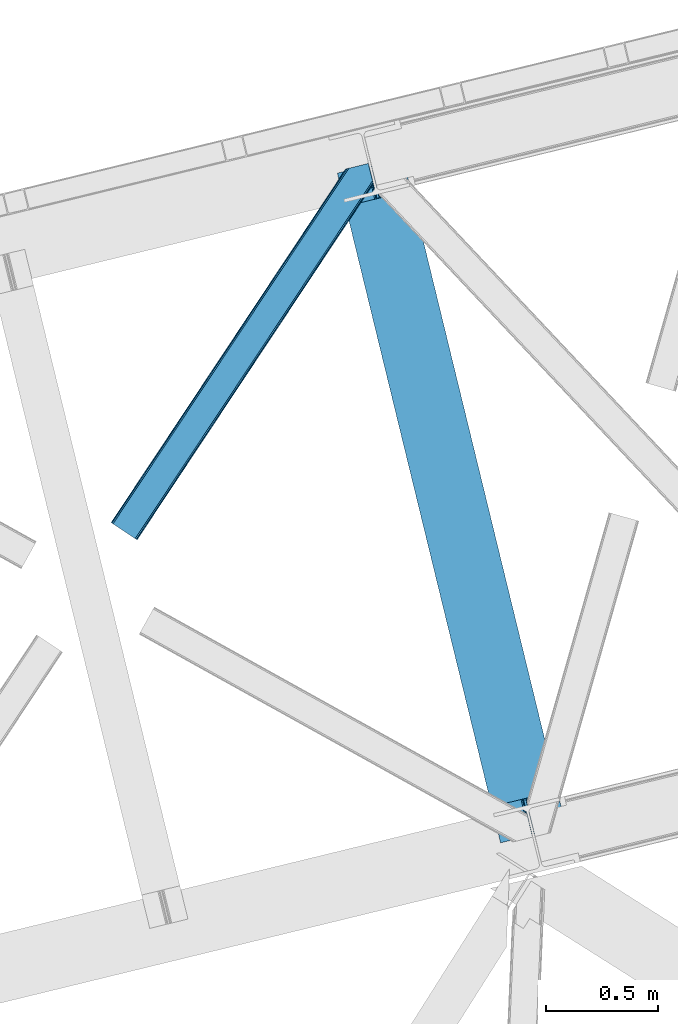
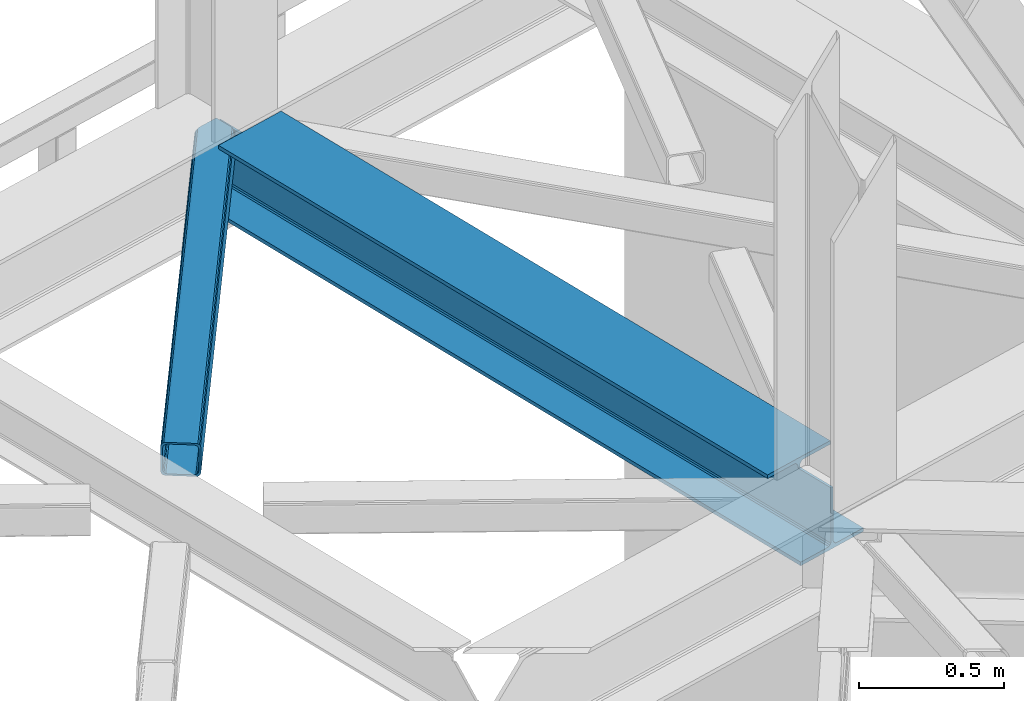
# One storey, part 84 of 92: 1 beam, 1 member.
"""IFC4 building model written with IfcOpenShell, lengths in millimetres."""

from ifc_helpers import new_model, entity, si_unit, converted_unit, derived_unit, direction, frame, origin, place, context, subcontext, project, spatial, triangles, polygons, material, type_object, element, save


model = new_model("IFC4")

# Units and contexts
model_context = context("Model", 3, precision=0.01, world=origin(), true_north=direction((6.12303176911189e-17, 1.0)))
plan_context = context("Plan", 3, precision=0.01, world=origin(), true_north=direction((6.12303176911189e-17, 1.0)))
body_context = subcontext(model_context, "Body", "Model", "MODEL_VIEW")
ifc_project = project(units=[si_unit("LENGTHUNIT", "METRE", prefix="MILLI"), si_unit("AREAUNIT", "SQUARE_METRE"), si_unit("VOLUMEUNIT", "CUBIC_METRE"), converted_unit("PLANEANGLEUNIT", "DEGREE", entity("IfcRatioMeasure", 0.0174532925199433), si_unit("PLANEANGLEUNIT", "RADIAN"), dimensions=[0, 0, 0, 0, 0, 0, 0]), si_unit("MASSUNIT", "GRAM", prefix="KILO"), derived_unit("MASSDENSITYUNIT", [(si_unit("MASSUNIT", "GRAM", prefix="KILO"), 1), (si_unit("LENGTHUNIT", "METRE"), -3)]), derived_unit("MOMENTOFINERTIAUNIT", [(si_unit("LENGTHUNIT", "METRE"), 4)]), si_unit("TIMEUNIT", "SECOND"), si_unit("FREQUENCYUNIT", "HERTZ"), si_unit("THERMODYNAMICTEMPERATUREUNIT", "DEGREE_CELSIUS"), derived_unit("THERMALTRANSMITTANCEUNIT", [(si_unit("MASSUNIT", "GRAM", prefix="KILO"), 1), (si_unit("THERMODYNAMICTEMPERATUREUNIT", "KELVIN"), -1), (si_unit("TIMEUNIT", "SECOND"), -3)]), derived_unit("VOLUMETRICFLOWRATEUNIT", [(si_unit("LENGTHUNIT", "METRE"), 3), (si_unit("TIMEUNIT", "SECOND"), -1)]), derived_unit("MASSFLOWRATEUNIT", [(si_unit("MASSUNIT", "GRAM", prefix="KILO"), 1), (si_unit("TIMEUNIT", "SECOND"), -1)]), derived_unit("ROTATIONALFREQUENCYUNIT", [(si_unit("TIMEUNIT", "SECOND"), -1)]), si_unit("ELECTRICCURRENTUNIT", "AMPERE"), si_unit("ELECTRICVOLTAGEUNIT", "VOLT"), si_unit("POWERUNIT", "WATT"), si_unit("FORCEUNIT", "NEWTON", prefix="KILO"), si_unit("ILLUMINANCEUNIT", "LUX"), si_unit("LUMINOUSFLUXUNIT", "LUMEN"), si_unit("LUMINOUSINTENSITYUNIT", "CANDELA"), derived_unit("USERDEFINED", [(si_unit("MASSUNIT", "GRAM", prefix="KILO"), -1), (si_unit("LENGTHUNIT", "METRE"), -2), (si_unit("TIMEUNIT", "SECOND"), 3), (si_unit("LUMINOUSFLUXUNIT", "LUMEN"), 1)]), derived_unit("LINEARVELOCITYUNIT", [(si_unit("LENGTHUNIT", "METRE"), 1), (si_unit("TIMEUNIT", "SECOND"), -1)]), si_unit("PRESSUREUNIT", "PASCAL"), derived_unit("USERDEFINED", [(si_unit("LENGTHUNIT", "METRE"), -2), (si_unit("MASSUNIT", "GRAM", prefix="KILO"), 1), (si_unit("TIMEUNIT", "SECOND"), -2)]), derived_unit("LINEARFORCEUNIT", [(si_unit("MASSUNIT", "GRAM", prefix="KILO"), 1), (si_unit("LENGTHUNIT", "METRE"), 1), (si_unit("TIMEUNIT", "SECOND"), -2), (si_unit("LENGTHUNIT", "METRE"), -1)]), derived_unit("PLANARFORCEUNIT", [(si_unit("MASSUNIT", "GRAM", prefix="KILO"), 1), (si_unit("LENGTHUNIT", "METRE"), 1), (si_unit("TIMEUNIT", "SECOND"), -2), (si_unit("LENGTHUNIT", "METRE"), -2)])], contexts=[model_context, plan_context])

# Site, building, storey
site_placement = place(None, origin())
site = spatial("IfcSite", under=ifc_project, at=site_placement, CompositionType="ELEMENT")
building_placement = place(site_placement, origin())
building = spatial("IfcBuilding", under=site, at=building_placement, CompositionType="ELEMENT")
storey_placement = place(building_placement, frame((0.0, 0.0, 15900.0)))
storey = spatial("IfcBuildingStorey", under=building, at=storey_placement, Name="05", CompositionType="ELEMENT", Elevation=15900.0)

# Beam
ifc_material = material(Name="Metal painted (White)")
beam_type = type_object("IfcBeamType", PredefinedType="BEAM")
beam_placement = place(storey_placement, frame((-3043.28, 17053.1, 3385.0)))
element("IfcBeam", 1, at=beam_placement, inside=storey, type_object=beam_type, material=ifc_material, ObjectType="Steel Beam", PredefinedType="BEAM", context=body_context, shape_type="Tessellation", body=[
    polygons([(1018.16648378329, 71.0478278971, 15.4999999999986), (1018.16648378329, 71.0478278971, 0.0), (291.465617442441, 3052.25531830421, 0.0), (291.46561744244, 3052.25531830421, 15.4999999999986), (894.779372399327, 40.970914087327, 15.4999999999986), (168.078506058477, 3022.17840449444, 15.4999999999986), (888.087028625373, 39.3395844888221, 16.8701684147941), (161.386162284522, 3020.54707489593, 16.8701684147941), (882.413533524753, 37.9566100336519, 20.7720779386369), (155.712667183903, 3019.16410044076, 20.7720779386369), (878.622625296174, 37.032536045914, 26.6116982174294), (151.921758955324, 3018.24002645303, 26.6116982174294), (877.29143535278, 36.7080444135029, 33.500000000001), (150.59056901193, 3017.91553482061, 33.500000000001), (140.875048430515, 3015.54727389071, 33.500000000001), (140.875048430516, 3015.54727389071, 259.000000000002), (150.590569011928, 3017.91553482061, 259.000000000002), (5.41433564649196e-13, 2981.20749040711, 0.0), (1.08286712929839e-12, 2981.20749040711, 15.4999999999986), (123.387111383957, 3011.28440421688, 15.4999999999986), (130.079455157929, 3012.91573381539, 16.8701684147963), (135.752950258545, 3014.29870827056, 20.7720779386369), (139.543858487118, 3015.22278225829, 26.6116982174294), (877.291435352778, 36.7080444135029, 259.000000000002), (867.575914771367, 34.3397834835992, 259.000000000002), (867.575914771365, 34.3397834835992, 33.500000000001), (866.244724827968, 34.0152918511816, 26.6116982174294), (862.453816599395, 33.0912178634502, 20.7720779386369), (856.78032149878, 31.70824340828, 16.8701684147963), (850.087977724808, 30.0769138097708, 15.4999999999986), (726.700866340852, -2.16573425859679e-12, 15.4999999999986), (726.700866340851, -2.16573425859679e-12, 0.0), (838.124523615906, 197.385937999179, 259.069791973884), (186.469722099963, 2870.72539801218, 259.000000000002), (186.693115201815, 2869.8089536072, 259.61730333112), (186.705504045442, 2869.75812937344, 266.500003008253), (837.97934480814, 197.9814160017, 266.500002998871), (837.979694928892, 197.979979696968, 260.000004007589), (828.499586345875, 194.645865944432, 259.006343171919), (828.276216326112, 195.562317481909, 259.61730333112), (828.263827482483, 195.613141715683, 266.500003008253), (176.989986719785, 2867.38985508742, 266.500002998871), (176.989636599033, 2867.39129139215, 260.000004007589), (176.844830940693, 2867.98534020594, 259.07612046749), (176.754201518551, 2868.35713708228, 259.000000000002), (839.310832678069, 198.30468544639, 273.388305639783), (843.101109266761, 199.231350618303, 279.227924098781), (848.7741802143, 200.616065081979, 283.129832400619), (855.466371895431, 202.248018612794, 284.500000377228), (978.853400583269, 232.325271667903, 284.500000138971), (978.851730776618, 232.332121736637, 299.999995328161), (687.386308679348, 161.283492472594, 299.999995890962), (687.387978485999, 161.276642403861, 284.500000701776), (810.775007173834, 191.35389545897, 284.500000463519), (817.467494069994, 192.984637925553, 283.129832461069), (823.141405718745, 194.365903570076, 279.227924137322), (826.932940505739, 195.28740721937, 273.388305663684), (175.658498849857, 2867.06658564273, 273.388305639783), (171.868222261161, 2866.13992047082, 279.227924098781), (166.195151313635, 2864.75520600714, 283.129832400619), (159.502959632485, 2863.12325247633, 284.500000377228), (36.115930944656, 2833.04599942122, 284.500000138971), (36.117600751305, 2833.03914935249, 299.999995328161), (327.583022848576, 2904.08777861653, 299.999995890962), (327.581353041926, 2904.09462868526, 284.500000701776), (204.194324354083, 2874.01737563015, 284.500000463519), (197.501837457941, 2872.38663316357, 283.129832461069), (191.827925809177, 2871.00536751904, 279.227924137322), (188.036391022187, 2870.08386386975, 273.388305663684)], [[[1, 2, 3, 4]], [[5, 1, 4, 6]], [[7, 5, 6, 8]], [[9, 7, 8, 10]], [[11, 9, 10, 12]], [[13, 11, 12, 14]], [[15, 16, 17, 14, 12, 10, 8, 6, 4, 3, 18, 19, 20, 21, 22, 23]], [[13, 24, 25, 26, 27, 28, 29, 30, 31, 32, 2, 1, 5, 7, 9, 11]], [[2, 32, 18, 3]], [[32, 31, 19, 18]], [[31, 30, 20, 19]], [[27, 26, 15, 23]], [[28, 27, 23, 22]], [[29, 28, 22, 21]], [[30, 29, 21, 20]], [[33, 24, 13, 14, 17, 34, 35, 36, 37, 38]], [[25, 39, 40, 41, 42, 43, 44, 16, 15, 26]], [[39, 25, 24, 33]], [[45, 34, 17, 16]], [[41, 40, 38, 37, 46, 47, 48, 49, 50, 51, 52, 53, 54, 55, 56, 57]], [[42, 58, 59, 60, 61, 62, 63, 64, 65, 66, 67, 68, 69, 36, 35, 43]], [[46, 37, 36, 69]], [[47, 46, 69, 68]], [[48, 47, 68, 67]], [[49, 48, 67, 66]], [[50, 49, 66, 65]], [[51, 50, 65, 64]], [[52, 51, 64, 63]], [[53, 52, 63, 62]], [[54, 53, 62, 61]], [[55, 54, 61, 60]], [[56, 55, 60, 59]], [[57, 56, 59, 58]], [[41, 57, 58, 42]]], closed=False),
])

# Member
member_type = type_object("IfcMemberType", PredefinedType="BRACE")
member_placement = place(storey_placement, frame((-4050.77, 18401.58, 3510.02)))
element("IfcMember", 2, at=member_placement, inside=storey, type_object=member_type, ObjectType="Steel Horizontal Brace", PredefinedType="BRACE", context=body_context, shape_type="Tessellation", body=[
    triangles([(1012.13822021484, 1571.4587310791, 0.0), (1045.99690933228, 1432.55790710449, 0.0), (14.5796333312987, 67.7191223144546, 0.0), (102.080397033692, 9.67499084472729, 0.0), (1.10807189941397, 76.6569488525383, 10.8039916992202), (0.0, 77.3929504394546, 17.5000946044929), (1043.79529953003, 1650.83760681152, 17.5000946044929), (1007.73296585083, 1592.73185119629, 9.25873718261573), (4.27125091552716, 74.5605651855476, 5.12643127441333), (1007.87191085815, 1593.1829864502, 9.50058288574292), (1007.5829750061, 1592.24815979004, 9.00061340332104), (1007.43734436035, 1591.76446838379, 8.74248962402271), (1007.29839935303, 1591.31333312989, 8.50064392089917), (1008.14776611328, 1587.8298248291, 5.12643127441333), (1046.0907989502, 1651.39571228027, 10.8702667236321), (1046.56518859863, 1651.51198425293, 9.50058288574292), (1009.97875900269, 1580.31865539551, 1.33247680664135), (9.00003204345694, 71.4212219238289, 1.33247680664135), (1043.79529953003, 1650.83760681152, 122.499499511719), (0.0, 77.3929504394546, 122.499499511719), (1045.70215988159, 1651.30269470215, 129.196765136719), (1.10807189941397, 76.6569488525383, 129.196765136719), (1051.1335144043, 1652.62586975098, 134.87548828125), (4.27125091552716, 74.5605651855476, 134.87548828125), (1059.25772781372, 1654.60481872559, 138.668280029298), (9.00003204345694, 71.4212219238289, 138.668280029298), (1068.84609603882, 1656.94421081543, 140.000756835936), (14.5796333312987, 67.7191223144546, 140.000756835936), (1012.24141159058, 1575.25849914551, 9.50058288574292), (1011.99578704834, 1574.65621032715, 9.42384338378906), (1012.03008728027, 1573.63069152832, 9.11688537597729), (1012.0707824707, 1572.60052185059, 8.80760192871094), (1012.10973358154, 1571.57732849121, 8.50064392089917), (1065.96342315674, 1656.23960266114, 9.50058288574292), (14.8357223510743, 67.5516906738303, 8.3320495605476), (20.4150329589843, 63.8495910644524, 7.00073547363354), (1014.39534988403, 1562.19883117676, 7.00073547363354), (10.1022903442381, 70.6898712158218, 12.1260040283196), (1061.15121688843, 1655.06758117676, 12.1260040283196), (1012.24228363037, 1571.03317565918, 8.41343994140698), (1055.7242225647, 1653.74440612793, 17.8035644531265), (1053.81300201416, 1653.27931823731, 24.5008300781265), (6.94376220703134, 72.7874176025398, 17.8035644531265), (5.83074874877912, 73.5234191894524, 24.5008300781265), (1043.73948898315, 1441.81780700684, 7.00073547363354), (96.244997406006, 13.5445220947258, 7.00073547363354), (1045.89284591675, 1432.98578796387, 8.41343994140698), (1046.02539596558, 1432.44163513184, 8.50064392089917), (1050.83643951416, 1412.70330505371, 8.50064392089917), (1049.98707275391, 1416.18913879395, 5.12643127441333), (1048.15637054443, 1423.69798278809, 1.33247680664135), (1053.81300201416, 1653.27931823731, 115.499926757813), (5.83074874877912, 73.5234191894524, 115.499926757813), (1069.28008117676, 1657.04885559082, 131.668707275392), (1078.86844940186, 1659.38592224121, 133.00118408203), (20.4150329589843, 63.8495910644524, 133.00118408203), (14.8357223510743, 67.5516906738303, 131.668707275392), (1061.15121688843, 1655.06758117676, 127.875915527344), (10.1022903442381, 70.6898712158218, 127.875915527344), (1055.7242225647, 1653.74440612793, 122.197192382813), (6.94376220703134, 72.7874176025398, 122.197192382813), (1145.26875686646, 1675.57098083496, 140.000756835936), (1145.26875686646, 1675.57098083496, 133.00118408203), (1161.91250839233, 1607.29375305176, 140.000756835936), (102.080397033692, 9.67499084472729, 140.000756835936), (1159.65537872314, 1616.5536529541, 133.00118408203), (96.244997406006, 13.5445220947258, 133.00118408203), (1164.07226028442, 1598.43382873535, 138.668280029298), (107.659998321533, 5.97289123535302, 138.668280029298), (1165.9029624939, 1590.92265930176, 134.87548828125), (112.388779449463, 2.83354797363427, 134.87548828125), (1167.12614364624, 1585.90436096191, 129.196765136719), (115.551958465576, 0.737164306639897, 129.196765136719), (1167.55576858521, 1584.14167785645, 122.499499511719), (116.660321044922, 0.0, 122.499499511719), (1167.55576858521, 1584.14167785645, 17.5000946044929), (116.660321044922, 0.0, 17.5000946044929), (106.557740020752, 6.7042419433601, 127.875915527344), (109.716268157959, 4.60553283691479, 122.197192382813), (110.829281616211, 3.87069396972583, 115.499926757813), (101.824308013916, 9.84125976562427, 131.668707275392), (115.551958465576, 0.737164306639897, 10.8039916992202), (106.557740020752, 6.7042419433601, 12.1260040283196), (112.388779449463, 2.83354797363427, 5.12643127441333), (110.829281616211, 3.87069396972583, 24.5008300781265), (109.716268157959, 4.60553283691479, 17.8035644531265), (107.659998321533, 5.97289123535302, 1.33247680664135), (101.824308013916, 9.84125976562427, 8.3320495605476), (1165.29834823608, 1593.40157775879, 115.499926757813), (1165.29834823608, 1593.40157775879, 24.5008300781265), (1164.86901397705, 1595.16426086426, 122.197192382813), (1163.64554214478, 1600.1825592041, 127.875915527344), (1161.8148399353, 1607.6937286377, 131.668707275392), (1164.7812286377, 1595.52470397949, 17.8698394775383), (1167.54646682739, 1584.18121032715, 16.5001556396492), (1164.67425842285, 1595.96188659668, 16.5001556396492), (1050.96404800415, 1412.49401550293, 8.8831787109375), (1051.5055847168, 1412.90561828614, 9.29943237304542), (1051.768359375, 1413.10328063965, 9.50058288574292), (1162.81652297974, 1579.82333679199, 10.8714294433594), (1161.66310501099, 1578.76061096192, 9.50058288574292), (1160.35097579956, 1595.22007141114, 12.1260040283196), (1046.70355224609, 1430.89521789551, 9.20757751464771), (1046.36229400635, 1431.66726379394, 8.85411071777344), (1047.39885864258, 1431.02776794434, 9.50058288574292), (1157.29360427856, 1596.68742370605, 9.50058288574292)], [[1, 2, 3], [4, 3, 2], [5, 6, 7], [8, 9, 10], [9, 8, 11], [12, 9, 11], [9, 12, 13], [13, 14, 9], [5, 15, 10], [10, 9, 5], [15, 16, 10], [17, 1, 18], [3, 18, 1], [14, 17, 9], [18, 9, 17], [7, 15, 5], [19, 7, 6], [6, 20, 19], [21, 19, 22], [20, 22, 19], [23, 21, 24], [22, 24, 21], [25, 23, 26], [24, 26, 23], [27, 25, 28], [26, 28, 25], [8, 10, 29], [11, 8, 30], [12, 11, 31], [13, 12, 32], [32, 33, 13], [31, 32, 12], [30, 31, 11], [29, 30, 8], [16, 34, 29], [29, 10, 16], [35, 36, 37], [38, 30, 29], [29, 39, 38], [29, 34, 39], [38, 35, 40], [40, 33, 38], [31, 38, 32], [31, 30, 38], [38, 33, 32], [37, 40, 35], [41, 42, 43], [44, 43, 42], [39, 41, 38], [43, 38, 41], [45, 37, 36], [36, 46, 45], [1, 37, 45], [13, 33, 14], [33, 40, 1], [37, 1, 40], [33, 17, 14], [33, 1, 17], [2, 1, 45], [2, 45, 47], [48, 2, 47], [49, 50, 48], [48, 51, 2], [48, 50, 51], [42, 52, 53], [53, 44, 42], [54, 55, 56], [56, 57, 54], [58, 54, 57], [57, 59, 58], [60, 58, 59], [59, 61, 60], [52, 60, 61], [61, 53, 52], [60, 19, 21], [54, 25, 27], [62, 55, 27], [55, 62, 63], [55, 54, 27], [58, 25, 54], [58, 60, 23], [23, 25, 58], [21, 23, 60], [42, 7, 19], [39, 16, 41], [60, 52, 19], [39, 34, 16], [42, 41, 7], [52, 42, 19], [15, 7, 41], [41, 16, 15], [64, 27, 65], [27, 64, 62], [28, 65, 27], [55, 66, 67], [55, 63, 66], [67, 56, 55], [68, 64, 65], [65, 69, 68], [70, 68, 69], [69, 71, 70], [72, 70, 71], [71, 73, 72], [74, 72, 73], [73, 75, 74], [76, 74, 75], [75, 77, 76], [73, 78, 79], [80, 77, 75], [73, 79, 75], [73, 71, 78], [79, 80, 75], [78, 71, 69], [67, 65, 28], [65, 81, 69], [81, 65, 67], [81, 78, 69], [82, 83, 84], [85, 77, 80], [77, 86, 82], [86, 77, 85], [82, 86, 83], [4, 46, 3], [87, 84, 83], [83, 88, 87], [88, 46, 4], [4, 87, 88], [59, 26, 24], [28, 56, 67], [28, 57, 56], [57, 28, 26], [59, 57, 26], [53, 20, 6], [22, 61, 59], [24, 22, 59], [61, 22, 20], [53, 61, 20], [18, 38, 9], [3, 46, 36], [36, 35, 3], [35, 38, 18], [18, 3, 35], [5, 9, 38], [6, 44, 53], [43, 6, 5], [6, 43, 44], [43, 5, 38], [89, 90, 80], [85, 80, 90], [91, 89, 79], [80, 79, 89], [92, 91, 78], [79, 78, 91], [93, 92, 81], [78, 81, 92], [66, 93, 67], [81, 67, 93], [94, 95, 96], [74, 76, 90], [76, 94, 90], [90, 89, 74], [76, 95, 94], [91, 74, 89], [72, 74, 91], [70, 91, 92], [91, 70, 72], [92, 68, 70], [93, 68, 92], [93, 66, 64], [93, 64, 68], [66, 62, 64], [66, 63, 62], [82, 97, 98], [99, 100, 82], [99, 101, 100], [84, 50, 97], [97, 82, 84], [77, 82, 100], [100, 76, 77], [100, 95, 76], [51, 50, 87], [84, 87, 50], [2, 51, 4], [87, 4, 51], [86, 85, 90], [86, 96, 102], [86, 94, 96], [103, 104, 88], [48, 88, 104], [83, 102, 105], [105, 88, 83], [102, 106, 105], [46, 88, 48], [48, 45, 46], [102, 83, 86], [90, 94, 86], [97, 48, 104], [97, 104, 105], [106, 101, 105], [99, 105, 101], [102, 95, 100], [102, 96, 95], [102, 101, 106], [100, 101, 102]]),
])

save(model, "model.ifc")
